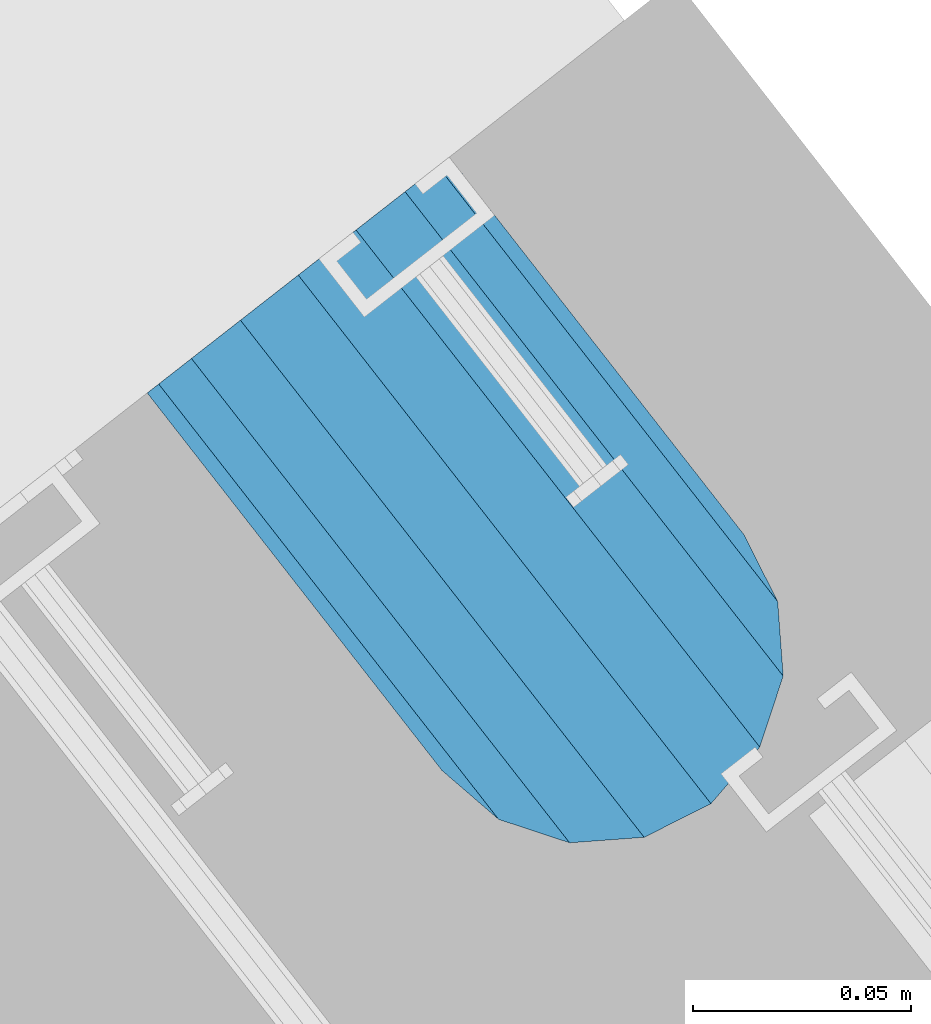
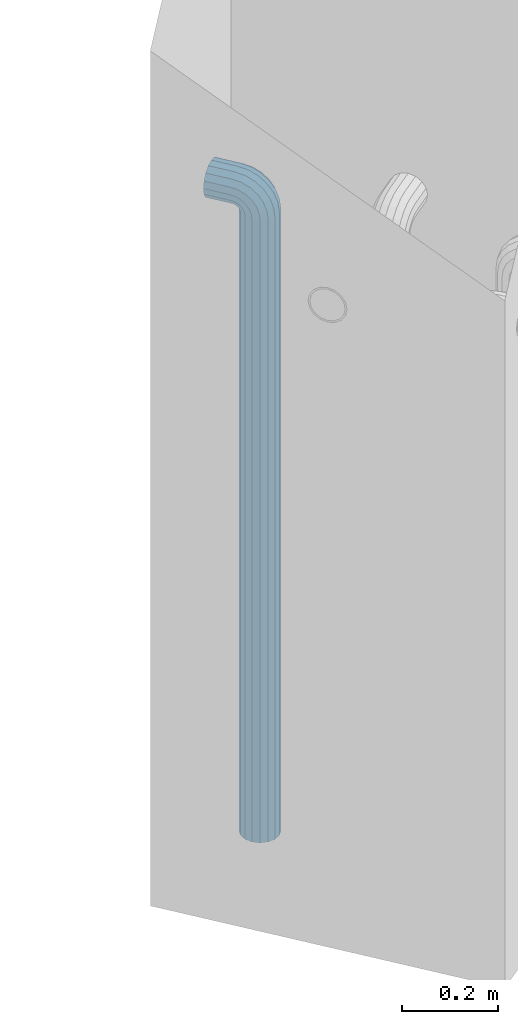
# One storey, part 5 of 42: 1 beam, 2 elements without a shape of their own.
"""IFC2X3 building model written with IfcOpenShell, lengths in millimetres."""

from ifc_helpers import new_model, si_unit, frame, origin_with_axes, place, context, subcontext, project, spatial, faceted_brep, material, type_object, element, aggregate, save


model = new_model("IFC2X3")

# Units and contexts
model_context = context("Model", 3, precision=1e-05, world=origin_with_axes())
body_context = subcontext(model_context, "Body", "Model", "MODEL_VIEW")
ifc_project = project(units=[si_unit("LENGTHUNIT", "METRE", prefix="MILLI"), si_unit("AREAUNIT", "SQUARE_METRE"), si_unit("VOLUMEUNIT", "CUBIC_METRE"), si_unit("MASSUNIT", "GRAM", prefix="KILO"), si_unit("TIMEUNIT", "SECOND"), si_unit("PLANEANGLEUNIT", "RADIAN"), si_unit("SOLIDANGLEUNIT", "STERADIAN"), si_unit("THERMODYNAMICTEMPERATUREUNIT", "DEGREE_CELSIUS"), si_unit("LUMINOUSINTENSITYUNIT", "LUMEN")], contexts=[model_context])

# Site, building, storey
site_placement = place(None, frame((171687.4, 84828.52, 14700.0), z_axis=(0.0, 0.0, 1.0), x_axis=(1.0, 0.0, 0.0)))
site = spatial("IfcSite", under=ifc_project, at=site_placement, CompositionType="ELEMENT")
building_placement = place(site_placement, origin_with_axes())
building = spatial("IfcBuilding", under=site, at=building_placement, Name="Undefined", CompositionType="ELEMENT")
storey_placement = place(building_placement, origin_with_axes())
storey = spatial("IfcBuildingStorey", under=building, at=storey_placement, Name="Undefined", CompositionType="ELEMENT", Elevation=0.0)

# Assemblies, beam
assembly_1_placement = place(storey_placement, origin_with_axes())
assembly_1 = element("IfcElementAssembly", 1, at=assembly_1_placement, inside=storey, AssemblyPlace="NOTDEFINED", PredefinedType="REINFORCEMENT_UNIT")
assembly_2_placement = place(assembly_1_placement, origin_with_axes())
assembly_2 = element("IfcElementAssembly", 2, at=assembly_2_placement, AssemblyPlace="NOTDEFINED", PredefinedType="RIGID_FRAME")
aggregate(assembly_1, [assembly_2])
ifc_material = material(Name="STEEL/NEG_BETON")
beam_type = type_object("IfcBeamType", PredefinedType="NOTDEFINED")
beam_placement = place(assembly_2_placement, frame((18008.9695688979, 265648.643267305, -1290.0), z_axis=(0.615386370178831, -0.788225611990706, 0.0), x_axis=(0.0, 0.0, 1.0)))
beam = element("IfcBeam", 3, at=beam_placement, type_object=beam_type, material=ifc_material, context=body_context, shape_type="Brep", body=[
    faceted_brep([(0.0, -43.999999753345, 2.88331648334861e-07), (0.0, -40.6506991838105, -16.8380707357428), (1590.0, -40.6506991838105, -16.8380707357428), (1589.99999999999, -43.999999753345, 2.88331648334861e-07), (0.0, -31.1126981254783, -31.1126980838017), (1590.0, -31.1126981254783, -31.1126980838017), (0.0, -16.8380707773322, -40.6506991419883), (1590.0, -16.8380707773322, -40.6506991419883), (0.0, 2.46742274612188e-07, -43.9999997114064), (1590.0, 2.46742274612188e-07, -43.9999997114064), (0.0, 16.8380712707876, -40.6506991418137), (1590.0, 16.8380712707876, -40.6506991418137), (0.0, 31.1126986189047, -31.1126980834524), (1590.0, 31.1126986189047, -31.1126980834524), (0.0, 40.6506996771204, -16.8380707352771), (1590.0, 40.6506996771204, -16.8380707352771), (0.0, 44.0000002465677, 2.88768205791712e-07), (1590.0, 44.0000002465677, 2.88768205791712e-07), (0.0, 40.6506996770622, 16.8380713128427), (1590.0, 40.6506996770622, 16.8380713128427), (0.0, 31.1126986187301, 31.1126986609306), (1590.0, 31.1126986187301, 31.1126986609306), (0.0, 16.8380712705839, 40.6506997191464), (1590.0, 16.8380712705839, 40.6506997191464), (0.0, 2.46509443968534e-07, 44.0000002885354), (1590.0, 2.46509443968534e-07, 44.0000002885354), (0.0, -16.8380707775359, 40.6506997189426), (1590.0, -16.8380707775359, 40.6506997189426), (0.0, -31.1126981256821, 31.1126986605814), (1590.0, -31.1126981256821, 31.1126986605814), (0.0, -40.6506991838978, 16.838071312377), (1590.0, -40.6506991838978, 16.838071312377), (4.47878846898675e-07, -40.0000000634464, 0.0), (4.47878846898675e-07, -36.9551813638827, 15.3073372946019), (1590.0, -36.9551810538396, 15.3073375829845), (1589.99999999999, -39.999999753345, 2.88360752165318e-07), (4.47937054559588e-07, -28.2842713108694, 28.284271247463), (1590.0, -28.2842710008845, 28.2842715359002), (4.4800981413573e-07, -15.3073373580119, 36.9551813004509), (1590.0, -15.3073370480561, 36.9551815889135), (4.48068021796644e-07, -6.34463503956795e-08, 40.0), (1590.0, 2.46538547798991e-07, 40.0000002885645), (4.48140781372786e-07, 15.3073372311774, 36.9551813004509), (1590.0, 15.3073375411332, 36.9551815890882), (4.48213540948927e-07, 28.2842711840058, 28.284271247463), (1590.0, 28.2842714939907, 28.2842715361621), (4.48271748609841e-07, 36.95518123699, 15.3073372946019), (1590.0, 36.9551815469749, 15.3073375833046), (4.48286300525069e-07, 39.9999999365536, 0.0), (1590.0, 40.0000002465677, 2.88768205791712e-07), (4.48271748609841e-07, 36.95518123699, -15.3073372946019), (1590.0, 36.9551815470913, -15.3073370058555), (4.48213540948927e-07, 28.2842711840058, -28.284271247463), (1590.0, 28.2842714941071, -28.2842709587712), (4.48140781372786e-07, 15.3073372311774, -36.9551813004509), (1590.0, 15.3073375413369, -36.9551810117846), (4.48068021796644e-07, -6.34463503956795e-08, -40.0), (1590.0, 2.46742274612188e-07, -39.9999997114064), (4.4800981413573e-07, -15.3073373580119, -36.9551813004509), (1590.0, -15.3073370479106, -36.9551810119592), (4.47937054559588e-07, -28.2842713108694, -28.284271247463), (1590.0, -28.284271000739, -28.2842709590332), (4.47878846898675e-07, -36.9551813638827, -15.3073372946019), (1590.0, -36.9551810537523, -15.3073370062048), (1602.94095225512, -43.9999997526465, -1.70370839745738), (1607.29896571893, -40.6506991831702, 14.560619269585), (1610.99351113838, -31.1126981249254, 28.3488504858688), (1613.46212746447, -16.8380707768374, 37.5618520393036), (1614.32899023963, 2.47237039729953e-07, 40.7970279594592), (1613.46212746447, 16.8380712712533, 37.5618520394491), (1610.99351113838, 31.1126986194577, 28.3488504861598), (1607.29896571893, 40.6506996777607, 14.5606192699925), (1602.94095225512, 44.0000002472952, -1.70370839699171), (1598.5829387913, 40.650699677848, -17.9680360640341), (1594.88839337186, 31.1126986196032, -31.7562672803178), (1592.41977704577, 16.8380712714861, -40.9692688337527), (1591.55291427061, 2.4744076654315e-07, -44.2044447539374), (1592.41977704577, -16.8380707766337, -40.9692688339564), (1594.88839337186, -31.1126981247508, -31.7562672806089), (1598.5829387913, -40.6506991830829, -17.9680360644415), (1613.29371405922, 2.47237039729953e-07, 36.9333246542956), (1612.50565699089, -15.3073370473576, 33.992255635967), (1610.26146033081, -28.284271000186, 25.6167996783042), (1606.90278267677, -36.9551810531411, 13.0820440271636), (1602.94095225512, -39.9999997526465, -1.70370839745738), (1598.97912183347, -36.9551810530538, -16.4894608219911), (1595.62044417943, -28.2842710000114, -29.0242164730153), (1593.37624751934, -15.3073370471539, -37.3996724305616), (1592.58819045102, 2.47411662712693e-07, -40.3407414487447), (1593.37624751934, 15.3073375420063, -37.3996724304452), (1595.62044417943, 28.2842714948347, -29.0242164727533), (1598.97912183347, 36.9551815478189, -16.4894608215836), (1602.94095225512, 40.0000002472952, -1.70370839699171), (1606.90278267677, 36.9551815477316, 13.082044027542), (1610.26146033081, 28.2842714946892, 25.6167996785662), (1612.50565699089, 15.3073375418317, 33.9922556361125), (1630.55634918609, -31.1126981248963, 20.2456576479599), (1635.32534971524, -16.8380707767792, 28.5058088658843), (1623.41903551202, -40.6506991831702, 7.88346773487865), (1614.99999999999, -43.9999997526465, -6.69872952270089), (1606.58096448796, -40.6506991830829, -21.2809267801931), (1599.44365081389, -31.1126981247799, -33.6431166932161), (1594.67465028474, -16.8380707766337, -41.9032679109368), (1592.99999999999, 2.4744076654315e-07, -44.8038472889457), (1594.67465028474, 16.8380712714861, -41.9032679107622), (1599.44365081389, 31.1126986195741, -33.6431166929251), (1606.58096448796, 40.650699677848, -21.2809267798148), (1614.99999999999, 44.0000002472952, -6.69872952226433), (1623.41903551202, 40.6506996777898, 7.88346773531521), (1630.55634918609, 31.1126986194577, 20.24565764828), (1635.32534971524, 16.8380712713115, 28.5058088660007), (1636.99999999999, 2.4726614356041e-07, 31.4063882440387), (1633.47759065022, 15.3073375418608, 25.3053962852573), (1634.99999999999, 2.4726614356041e-07, 27.9422866288805), (1629.14213562372, 28.2842714947183, 17.7961679055006), (1622.65366864729, 36.9551815477607, 6.55781343916897), (1614.99999999999, 40.0000002473244, -6.69872952226433), (1607.34633135269, 36.9551815477898, -19.9552724836976), (1600.85786437626, 28.2842714948347, -31.1936269501166), (1596.52240934976, 15.3073375420354, -38.7028553300188), (1594.99999999999, 2.47411662712693e-07, -41.3397456738458), (1596.52240934976, -15.3073370471539, -38.7028553301352), (1600.85786437626, -28.2842710000696, -31.1936269504367), (1607.34633135269, -36.9551810530538, -19.9552724840469), (1614.99999999999, -39.9999997526465, -6.69872952267178), (1622.65366864729, -36.955181053112, 6.55781343879062), (1629.14213562372, -28.2842710001278, 17.7961679052387), (1633.47759065022, -15.3073370472994, 25.3053962851118), (1647.35533905931, -31.1126981248963, 7.35533934747218), (1654.09972428659, -16.8380707767792, 14.0997245748003), (1637.26165326253, -40.6506991831411, -2.73834644936142), (1625.35533905931, -43.9999997526174, -14.644660652586), (1613.4490248561, -40.650699183112, -26.5509748557815), (1603.35533905931, -31.1126981247508, -36.6446606524696), (1596.61095383203, -16.8380707766046, -43.3890458796814), (1594.24264068711, 2.4744076654315e-07, -45.7573590245447), (1596.61095383203, 16.8380712714861, -43.3890458795358), (1603.35533905931, 31.1126986196032, -36.6446606521786), (1613.4490248561, 40.6506996778771, -26.550974855345), (1625.35533905931, 44.0000002473244, -14.6446606521204), (1637.26165326253, 40.6506996778189, -2.73834644892486), (1647.35533905931, 31.1126986194868, 7.35533934779232), (1654.09972428659, 16.8380712713406, 14.0997245750041), (1656.46803743151, 2.47295247390866e-07, 16.4680377198383), (1651.48659835683, 15.3073375418899, 11.4865986451914), (1653.63961030677, 2.47295247390866e-07, 13.6396105950989), (1645.35533905931, 28.2842714947474, 5.35533934776322), (1636.17926106223, 36.9551815477607, -3.82073864925769), (1625.35533905931, 40.0000002473244, -14.6446606521204), (1614.53141705639, 36.9551815478189, -25.4685826550995), (1605.35533905931, 28.2842714948638, -34.6446606522077), (1599.22407976179, 15.3073375420063, -40.7759199497814), (1597.07106781185, 2.4744076654315e-07, -42.9289318997762), (1599.22407976179, -15.3073370471539, -40.7759199499269), (1605.35533905931, -28.2842710000405, -34.6446606524696), (1614.53141705639, -36.9551810530247, -25.4685826554487), (1625.35533905931, -39.9999997526174, -14.644660652586), (1636.17926106223, -36.9551810530829, -3.82073864963604), (1645.35533905931, -28.2842710001278, 5.35533934750129), (1651.48659835683, -15.3073370472994, 11.486598645075), (1660.24565735981, -31.1126981248381, -9.44365052573266), (1668.50580857761, -16.838070776721, -4.67464999653748), (1647.88346744676, -40.6506991830829, -16.5809641998203), (1633.3012701892, -43.9999997525592, -24.9999997119012), (1618.71907293164, -40.6506991830538, -33.4190352238948), (1606.35688301859, -31.1126981247508, -40.5563488978951), (1598.09673180079, -16.8380707766337, -45.3253494270029), (1595.19615242269, 2.47469870373607e-07, -46.9999997116392), (1598.09673180079, 16.8380712714861, -45.3253494267992), (1606.35688301859, 31.1126986196032, -40.556348897604), (1618.71907293164, 40.6506996778771, -33.4190352235164), (1633.3012701892, 44.0000002473535, -24.9999997114355), (1647.88346744676, 40.650699677848, -16.580964199442), (1660.24565735981, 31.1126986195159, -9.44365052544163), (1668.50580857761, 16.8380712713988, -4.67464999633376), (1671.40638795571, 2.47324351221323e-07, -2.99999971169746), (1665.30539599684, 15.307337541919, -6.52240906140651), (1667.94228634057, 2.47324351221323e-07, -4.99999971172656), (1657.79616761703, 28.2842714948056, -10.8578640878259), (1646.55781315062, 36.9551815477898, -17.3463310641819), (1633.3012701892, 40.0000002473826, -24.9999997114355), (1620.04472722778, 36.955181547848, -32.6536683587765), (1608.80637276137, 28.2842714948638, -39.1421353352489), (1601.29714438156, 15.3073375420063, -43.4775903618138), (1598.66025403783, 2.47469870373607e-07, -44.9999997116392), (1601.29714438156, -15.3073370471539, -43.4775903619302), (1608.80637276137, -28.2842710000114, -39.1421353355108), (1620.04472722778, -36.9551810530247, -32.6536683591548), (1633.3012701892, -39.9999997525883, -24.9999997119012), (1646.55781315062, -36.9551810530538, -17.3463310645602), (1657.79616761703, -28.2842710000987, -10.8578640880878), (1665.30539599684, -15.3073370472412, -6.52240906155203), (1668.34885019768, -31.1126981247799, -29.0064885734755), (1677.56185175105, -16.8380707766628, -26.5378722472815), (1654.56061898146, -40.6506991830538, -32.7010339929548), (1638.29629131443, -43.9999997525592, -37.0590474567725), (1622.0319636474, -40.6506991830538, -41.4170609205903), (1608.24373243118, -31.1126981247508, -45.111606339924), (1599.03073087781, -16.8380707766046, -47.5802226659725), (1595.79555495772, 2.47469870373607e-07, -48.447085441032), (1599.03073087781, 16.8380712715152, -47.5802226657979), (1608.24373243118, 31.1126986196032, -45.1116063396621), (1622.0319636474, 40.6506996779062, -41.4170609201537), (1638.29629131443, 44.0000002474117, -37.059047456336), (1654.56061898146, 40.6506996778771, -32.7010339925182), (1668.34885019768, 31.112698619545, -29.0064885731554), (1677.56185175105, 16.8380712714279, -26.537872247136), (1680.79702767114, 2.47382558882236e-07, -25.6710094720474), (1673.99225534772, 15.3073375420063, -27.494342720689), (1676.93332436598, 2.47382558882236e-07, -26.7062856524717), (1665.61679939011, 28.2842714948056, -29.738539380749), (1653.082043739, 36.9551815478189, -33.0972170347231), (1638.29629131443, 40.0000002473826, -37.059047456336), (1623.51053888986, 36.955181547848, -41.0208778779779), (1610.97578323875, 28.2842714948929, -44.3795555320976), (1602.60032728114, 15.3073375420354, -46.6237521922449), (1599.65925826287, 2.4744076654315e-07, -47.4118092606659), (1602.60032728114, -15.3073370471539, -46.6237521923613), (1610.97578323875, -28.2842710000114, -44.3795555323595), (1623.51053888986, -36.9551810529956, -41.0208778783854), (1638.29629131443, -39.9999997525592, -37.0590474567725), (1653.082043739, -36.9551810529956, -33.0972170350724), (1665.61679939011, -28.2842710000405, -29.73853938104), (1673.99225534772, -15.3073370472121, -27.4943427208927), (1608.88730162777, -31.1126981247216, -49.9999997117848), (1623.16192897591, -40.6506991830247, -49.9999997118721), (1599.34930056949, -16.8380707766046, -49.9999997117557), (1595.99999999998, 2.47469870373607e-07, -49.9999997116684), (1599.34930056949, 16.8380712715152, -49.9999997115519), (1608.88730162777, 31.1126986196323, -49.9999997115228), (1623.16192897591, 40.6506996779353, -49.9999997114355), (1639.99999999997, 44.0000002473826, -49.9999997114646), (1656.83807102403, 40.6506996779353, -49.9999997114355), (1671.11269837217, 31.1126986196323, -49.9999997115228), (1680.65069943045, 16.8380712715152, -49.9999997115519), (1683.99999999996, 2.47469870373607e-07, -49.9999997116684), (1680.65069943045, -16.8380707766046, -49.9999997117557), (1671.11269837217, -31.1126981247216, -49.9999997117848), (1656.83807102403, -40.6506991830247, -49.9999997118721), (1640.0, -43.999999752501, -49.9999997118721), (1676.95518130041, 15.3073375420354, -49.9999997116101), (1679.99999999996, 2.47469870373607e-07, -49.9999997116684), (1668.28427124742, 28.2842714948929, -49.9999997114937), (1655.30733729457, 36.9551815478771, -49.9999997114937), (1639.99999999997, 40.0000002474117, -49.9999997114937), (1624.69266270537, 36.9551815478771, -49.9999997114937), (1611.71572875252, 28.2842714948929, -49.9999997114937), (1603.04481869953, 15.3073375420354, -49.9999997116101), (1599.99999999998, 2.47469870373607e-07, -49.9999997116684), (1603.04481869953, -15.3073370471539, -49.9999997117266), (1611.71572875252, -28.2842710000114, -49.9999997118139), (1624.69266270537, -36.9551810529665, -49.9999997118139), (1640.0, -39.9999997525301, -49.999999711843), (1655.30733729457, -36.9551810529665, -49.999999711843), (1668.28427124742, -28.2842710000114, -49.9999997118139), (1676.95518130041, -15.3073370471247, -49.9999997117266), (1623.16192897594, -40.6506991828792, -109.999999711843), (1640.0, -43.9999997523555, -109.999999711843), (1608.88730162779, -31.1126981245761, -109.999999711785), (1599.3493005695, -16.8380707764591, -109.999999711727), (1596.0, 2.4761538952589e-07, -109.999999711639), (1599.3493005695, 16.8380712716607, -109.999999711552), (1608.88730162779, 31.1126986197778, -109.999999711494), (1623.16192897594, 40.6506996780809, -109.999999711406), (1640.0, 44.0000002475572, -109.999999711436), (1656.83807102406, 40.6506996780809, -109.999999711406), (1671.11269837221, 31.1126986197778, -109.999999711494), (1680.6506994305, 16.8380712716607, -109.999999711552), (1684.0, 2.4761538952589e-07, -109.999999711639), (1680.6506994305, -16.8380707764591, -109.999999711727), (1671.11269837221, -31.1126981245761, -109.999999711785), (1656.83807102406, -40.6506991828792, -109.999999711843), (1655.3073372946, -36.9551810527919, -109.999999711785), (1640.0, -39.9999997523846, -109.999999711843), (1668.28427124746, -28.2842709998658, -109.999999711785), (1676.95518130045, -15.3073370469792, -109.999999711727), (1680.0, 2.4761538952589e-07, -109.999999711639), (1676.95518130045, 15.3073375421809, -109.999999711581), (1668.28427124746, 28.2842714950675, -109.999999711465), (1655.3073372946, 36.9551815479936, -109.999999711465), (1640.0, 40.0000002475572, -109.999999711465), (1624.6926627054, 36.9551815479936, -109.999999711465), (1611.71572875254, 28.2842714950675, -109.999999711465), (1603.04481869955, 15.3073375421809, -109.999999711581), (1600.0, 2.4761538952589e-07, -109.999999711639), (1603.04481869955, -15.3073370469792, -109.999999711727), (1611.71572875254, -28.2842709998658, -109.999999711785), (1624.6926627054, -36.9551810527919, -109.999999711785)], [[[0, 1, 2, 3]], [[1, 4, 5, 2]], [[4, 6, 7, 5]], [[6, 8, 9, 7]], [[8, 10, 11, 9]], [[10, 12, 13, 11]], [[12, 14, 15, 13]], [[14, 16, 17, 15]], [[16, 18, 19, 17]], [[18, 20, 21, 19]], [[20, 22, 23, 21]], [[22, 24, 25, 23]], [[24, 26, 27, 25]], [[26, 28, 29, 27]], [[28, 30, 31, 29]], [[30, 0, 3, 31]], [[32, 33, 34, 35]], [[33, 36, 37, 34]], [[36, 38, 39, 37]], [[38, 40, 41, 39]], [[40, 42, 43, 41]], [[42, 44, 45, 43]], [[44, 46, 47, 45]], [[46, 48, 49, 47]], [[48, 50, 51, 49]], [[50, 52, 53, 51]], [[52, 54, 55, 53]], [[54, 56, 57, 55]], [[56, 58, 59, 57]], [[58, 60, 61, 59]], [[60, 62, 63, 61]], [[62, 32, 35, 63]], [[30, 28, 26, 24, 22, 20, 18, 16, 14, 12, 10, 8, 6, 4, 1, 0], [62, 60, 58, 56, 54, 52, 50, 48, 46, 44, 42, 40, 38, 36, 33, 32]], [[31, 3, 64, 65]], [[29, 31, 65, 66]], [[27, 29, 66, 67]], [[25, 27, 67, 68]], [[23, 25, 68, 69]], [[21, 23, 69, 70]], [[19, 21, 70, 71]], [[17, 19, 71, 72]], [[15, 17, 72, 73]], [[13, 15, 73, 74]], [[11, 13, 74, 75]], [[9, 11, 75, 76]], [[7, 9, 76, 77]], [[5, 7, 77, 78]], [[2, 5, 78, 79]], [[3, 2, 79, 64]], [[39, 41, 80, 81]], [[37, 39, 81, 82]], [[34, 37, 82, 83]], [[35, 34, 83, 84]], [[63, 35, 84, 85]], [[61, 63, 85, 86]], [[59, 61, 86, 87]], [[57, 59, 87, 88]], [[55, 57, 88, 89]], [[53, 55, 89, 90]], [[51, 53, 90, 91]], [[49, 51, 91, 92]], [[47, 49, 92, 93]], [[45, 47, 93, 94]], [[43, 45, 94, 95]], [[41, 43, 95, 80]], [[66, 96, 97, 67]], [[65, 98, 96, 66]], [[64, 99, 98, 65]], [[79, 100, 99, 64]], [[78, 101, 100, 79]], [[77, 102, 101, 78]], [[76, 103, 102, 77]], [[75, 104, 103, 76]], [[74, 105, 104, 75]], [[73, 106, 105, 74]], [[72, 107, 106, 73]], [[71, 108, 107, 72]], [[70, 109, 108, 71]], [[69, 110, 109, 70]], [[68, 111, 110, 69]], [[67, 97, 111, 68]], [[95, 112, 113, 80]], [[94, 114, 112, 95]], [[93, 115, 114, 94]], [[92, 116, 115, 93]], [[91, 117, 116, 92]], [[90, 118, 117, 91]], [[89, 119, 118, 90]], [[88, 120, 119, 89]], [[87, 121, 120, 88]], [[86, 122, 121, 87]], [[85, 123, 122, 86]], [[84, 124, 123, 85]], [[83, 125, 124, 84]], [[82, 126, 125, 83]], [[81, 127, 126, 82]], [[80, 113, 127, 81]], [[96, 128, 129, 97]], [[98, 130, 128, 96]], [[99, 131, 130, 98]], [[100, 132, 131, 99]], [[101, 133, 132, 100]], [[102, 134, 133, 101]], [[103, 135, 134, 102]], [[104, 136, 135, 103]], [[105, 137, 136, 104]], [[106, 138, 137, 105]], [[107, 139, 138, 106]], [[108, 140, 139, 107]], [[109, 141, 140, 108]], [[110, 142, 141, 109]], [[111, 143, 142, 110]], [[97, 129, 143, 111]], [[112, 144, 145, 113]], [[114, 146, 144, 112]], [[115, 147, 146, 114]], [[116, 148, 147, 115]], [[117, 149, 148, 116]], [[118, 150, 149, 117]], [[119, 151, 150, 118]], [[120, 152, 151, 119]], [[121, 153, 152, 120]], [[122, 154, 153, 121]], [[123, 155, 154, 122]], [[124, 156, 155, 123]], [[125, 157, 156, 124]], [[126, 158, 157, 125]], [[127, 159, 158, 126]], [[113, 145, 159, 127]], [[128, 160, 161, 129]], [[130, 162, 160, 128]], [[131, 163, 162, 130]], [[132, 164, 163, 131]], [[133, 165, 164, 132]], [[134, 166, 165, 133]], [[135, 167, 166, 134]], [[136, 168, 167, 135]], [[137, 169, 168, 136]], [[138, 170, 169, 137]], [[139, 171, 170, 138]], [[140, 172, 171, 139]], [[141, 173, 172, 140]], [[142, 174, 173, 141]], [[143, 175, 174, 142]], [[129, 161, 175, 143]], [[144, 176, 177, 145]], [[146, 178, 176, 144]], [[147, 179, 178, 146]], [[148, 180, 179, 147]], [[149, 181, 180, 148]], [[150, 182, 181, 149]], [[151, 183, 182, 150]], [[152, 184, 183, 151]], [[153, 185, 184, 152]], [[154, 186, 185, 153]], [[155, 187, 186, 154]], [[156, 188, 187, 155]], [[157, 189, 188, 156]], [[158, 190, 189, 157]], [[159, 191, 190, 158]], [[145, 177, 191, 159]], [[160, 192, 193, 161]], [[162, 194, 192, 160]], [[163, 195, 194, 162]], [[164, 196, 195, 163]], [[165, 197, 196, 164]], [[166, 198, 197, 165]], [[167, 199, 198, 166]], [[168, 200, 199, 167]], [[169, 201, 200, 168]], [[170, 202, 201, 169]], [[171, 203, 202, 170]], [[172, 204, 203, 171]], [[173, 205, 204, 172]], [[174, 206, 205, 173]], [[175, 207, 206, 174]], [[161, 193, 207, 175]], [[176, 208, 209, 177]], [[178, 210, 208, 176]], [[179, 211, 210, 178]], [[180, 212, 211, 179]], [[181, 213, 212, 180]], [[182, 214, 213, 181]], [[183, 215, 214, 182]], [[184, 216, 215, 183]], [[185, 217, 216, 184]], [[186, 218, 217, 185]], [[187, 219, 218, 186]], [[188, 220, 219, 187]], [[189, 221, 220, 188]], [[190, 222, 221, 189]], [[191, 223, 222, 190]], [[177, 209, 223, 191]], [[197, 224, 225, 196]], [[198, 226, 224, 197]], [[199, 227, 226, 198]], [[200, 228, 227, 199]], [[201, 229, 228, 200]], [[202, 230, 229, 201]], [[203, 231, 230, 202]], [[204, 232, 231, 203]], [[205, 233, 232, 204]], [[206, 234, 233, 205]], [[207, 235, 234, 206]], [[193, 236, 235, 207]], [[192, 237, 236, 193]], [[194, 238, 237, 192]], [[195, 239, 238, 194]], [[196, 225, 239, 195]], [[208, 240, 241, 209]], [[210, 242, 240, 208]], [[211, 243, 242, 210]], [[212, 244, 243, 211]], [[213, 245, 244, 212]], [[214, 246, 245, 213]], [[215, 247, 246, 214]], [[216, 248, 247, 215]], [[217, 249, 248, 216]], [[218, 250, 249, 217]], [[219, 251, 250, 218]], [[220, 252, 251, 219]], [[221, 253, 252, 220]], [[222, 254, 253, 221]], [[223, 255, 254, 222]], [[209, 241, 255, 223]], [[239, 225, 256, 257]], [[225, 224, 258, 256]], [[224, 226, 259, 258]], [[226, 227, 260, 259]], [[227, 228, 261, 260]], [[228, 229, 262, 261]], [[229, 230, 263, 262]], [[230, 231, 264, 263]], [[231, 232, 265, 264]], [[232, 233, 266, 265]], [[233, 234, 267, 266]], [[234, 235, 268, 267]], [[235, 236, 269, 268]], [[236, 237, 270, 269]], [[237, 238, 271, 270]], [[238, 239, 257, 271]], [[252, 253, 272, 273]], [[253, 254, 274, 272]], [[254, 255, 275, 274]], [[255, 241, 276, 275]], [[241, 240, 277, 276]], [[240, 242, 278, 277]], [[242, 243, 279, 278]], [[243, 244, 280, 279]], [[244, 245, 281, 280]], [[245, 246, 282, 281]], [[246, 247, 283, 282]], [[247, 248, 284, 283]], [[248, 249, 285, 284]], [[249, 250, 286, 285]], [[250, 251, 287, 286]], [[251, 252, 273, 287]], [[258, 259, 260, 261, 262, 263, 264, 265, 266, 267, 268, 269, 270, 271, 257, 256], [274, 275, 276, 277, 278, 279, 280, 281, 282, 283, 284, 285, 286, 287, 273, 272]]]),
])
aggregate(assembly_2, [beam])

save(model, "model.ifc")
